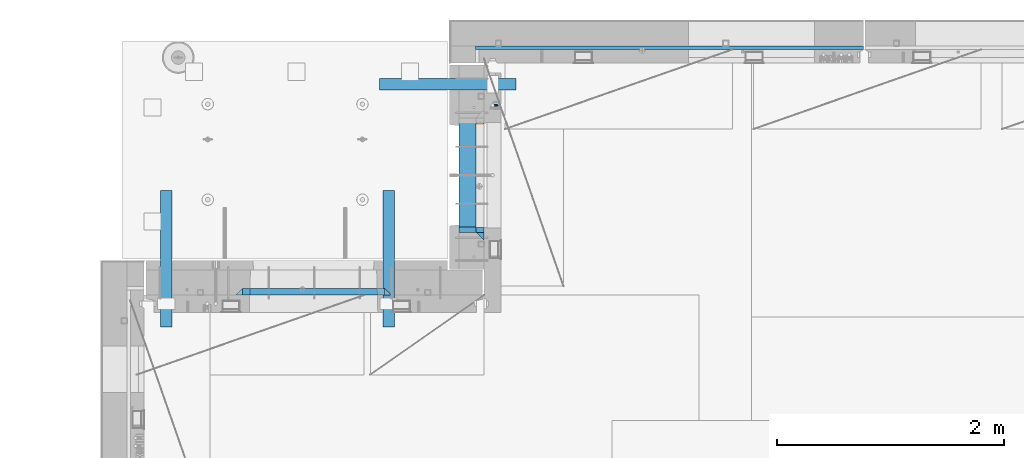
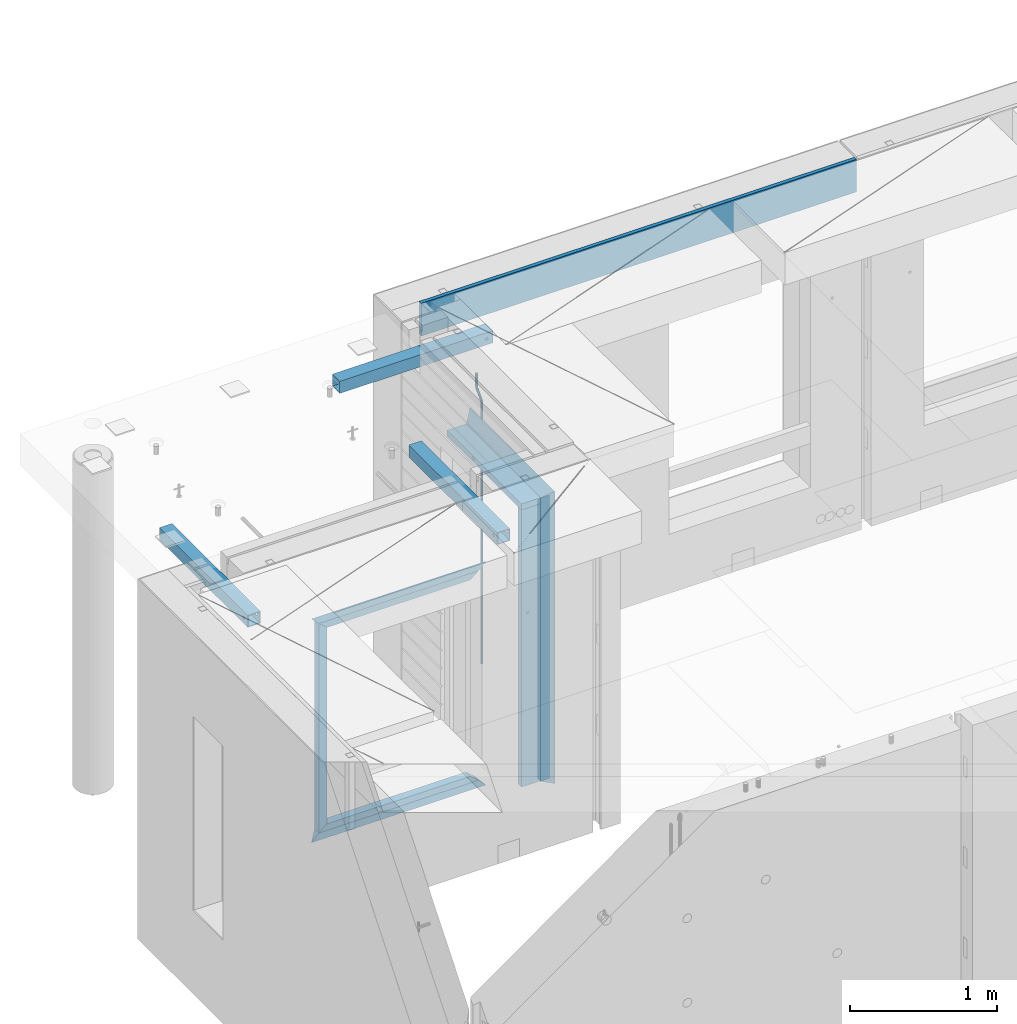
# One storey, part 99 of 309: 15 beams, 7 elements without a shape of their own.
"""IFC2X3 building model written with IfcOpenShell, lengths in millimetres."""

from ifc_helpers import new_model, si_unit, frame, origin_with_axes, place, context, subcontext, project, spatial, faceted_brep, material, type_object, element, aggregate, save


model = new_model("IFC2X3")

# Units and contexts
model_context = context("Model", 3, precision=1e-05, world=origin_with_axes())
body_context = subcontext(model_context, "Body", "Model", "MODEL_VIEW")
ifc_project = project(units=[si_unit("LENGTHUNIT", "METRE", prefix="MILLI"), si_unit("AREAUNIT", "SQUARE_METRE"), si_unit("VOLUMEUNIT", "CUBIC_METRE"), si_unit("MASSUNIT", "GRAM", prefix="KILO"), si_unit("TIMEUNIT", "SECOND"), si_unit("PLANEANGLEUNIT", "RADIAN"), si_unit("SOLIDANGLEUNIT", "STERADIAN"), si_unit("THERMODYNAMICTEMPERATUREUNIT", "DEGREE_CELSIUS"), si_unit("LUMINOUSINTENSITYUNIT", "LUMEN")], contexts=[model_context])

# Site, building, storey
site_placement = place(None, origin_with_axes())
site = spatial("IfcSite", under=ifc_project, at=site_placement, CompositionType="ELEMENT")
building_placement = place(site_placement, origin_with_axes())
building = spatial("IfcBuilding", under=site, at=building_placement, CompositionType="ELEMENT")
storey_placement = place(building_placement, origin_with_axes())
storey = spatial("IfcBuildingStorey", under=building, at=storey_placement, Name="7", CompositionType="ELEMENT", Elevation=0.0)

# Assembly, beams
assembly_1_placement = place(storey_placement, origin_with_axes())
assembly_1 = element("IfcElementAssembly", 1, at=assembly_1_placement, inside=storey, AssemblyPlace="NOTDEFINED", PredefinedType="REINFORCEMENT_UNIT")
ifc_material_1 = material(Name="CONCRETE/C25/30")
beam_type_1 = type_object("IfcBeamType", PredefinedType="NOTDEFINED")
beam_1_placement = place(assembly_1_placement, frame((10955.0, 22209.9998901814, 102140.0), z_axis=(0.0, 0.0, -1.0), x_axis=(0.0, -1.0, 0.0)))
beam_1 = element("IfcBeam", 2, at=beam_1_placement, type_object=beam_type_1, material=ifc_material_1, Name="SK", context=body_context, shape_type="Brep", body=[
    faceted_brep([(70.0000000000164, -35.0, 35.0), (70.0000000000164, 35.0, 35.0), (0.0, -35.0, -35.0), (1079.99961853027, -35.0, 35.0), (1079.99961853027, 35.0, 35.0), (1149.99961853027, -35.0, -35.0)], [[[0, 1, 2]], [[1, 0, 3, 4]], [[2, 1, 4, 5]], [[0, 2, 5, 3]], [[5, 4, 3]]]),
])
beam_2_placement = place(assembly_1_placement, frame((10955.0, 21095.0002716511, 102175.0), z_axis=(0.0, 1.0, 0.0), x_axis=(0.0, 0.0, -1.0)))
beam_2 = element("IfcBeam", 3, at=beam_2_placement, type_object=beam_type_1, material=ifc_material_1, Name="SK", context=body_context, shape_type="Brep", body=[
    faceted_brep([(2420.0, -35.0, 35.0), (2420.0, -35.0, -35.0), (2420.0, 35.0, 35.0), (70.0000000000164, -35.0, 35.0), (0.0, -35.0, -35.0), (70.0000000000164, 35.0, 35.0)], [[[0, 1, 2]], [[1, 0, 3, 4]], [[2, 1, 4, 5]], [[0, 2, 5, 3]], [[3, 5, 4]]]),
])
beam_type_2 = type_object("IfcBeamType", PredefinedType="NOTDEFINED")
beam_3_placement = place(assembly_1_placement, frame((10955.0, 21155.0002716511, 102105.0), z_axis=(0.0, 1.0, 0.0), x_axis=(0.0, 0.0, -1.0)))
beam_3 = element("IfcBeam", 4, at=beam_3_placement, type_object=beam_type_2, material=ifc_material_1, Name="SK", context=body_context, shape_type="Brep", body=[
    faceted_brep([(2350.0, -35.0, -25.0), (2350.0, 35.0, -25.0), (2350.0, 35.0, 20.6410256410309), (2350.0, -35.0, 18.8461538461561), (43.8461538461561, -35.0, 18.8461538461543), (0.0, -35.0, -25.0), (0.0, 35.0, -25.0), (45.6410256410309, 35.0, 20.6410256410254)], [[[0, 1, 2, 3]], [[0, 3, 4, 5]], [[1, 0, 5, 6]], [[2, 1, 6, 7]], [[3, 2, 7, 4]], [[7, 6, 5, 4]]]),
])
ifc_material_2 = material(Name="TIMBER")
beam_type_3 = type_object("IfcBeamType", Name="50X150", PredefinedType="NOTDEFINED")
beam_4_placement = place(assembly_1_placement, frame((10845.0, 22139.9998901814, 102080.0), z_axis=(0.0, 0.0, -1.0), x_axis=(0.0, -1.0, 0.0)))
beam_4 = element("IfcBeam", 5, at=beam_4_placement, type_object=beam_type_3, material=ifc_material_2, ObjectType="50X150", context=body_context, shape_type="Brep", body=[
    faceted_brep([(0.0, 75.0, -25.0), (1.81898940354586e-12, 75.0, 25.0), (1009.99961853027, 75.0, 25.0), (1009.99961853027, 75.0, -25.0), (1.81898940354586e-12, -75.0000000000009, 25.0), (1009.99961853027, -75.0, 25.0), (0.0, -75.0, -25.0), (1009.99961853027, -75.0, -25.0)], [[[0, 1, 2, 3]], [[1, 4, 5, 2]], [[4, 6, 7, 5]], [[6, 0, 3, 7]], [[5, 7, 3, 2]], [[6, 4, 1, 0]]]),
])
beam_5_placement = place(assembly_1_placement, frame((10845.0, 21155.0002716511, 102055.0), z_axis=(0.0, 1.0, 0.0), x_axis=(0.0, 0.0, -1.0)))
beam_5 = element("IfcBeam", 6, at=beam_5_placement, type_object=beam_type_3, material=ifc_material_2, ObjectType="50X150", context=body_context, shape_type="Brep", body=[
    faceted_brep([(0.0, 75.0, -25.0), (1.81898940354586e-12, 75.0, 25.0), (2295.00000000001, 75.0, 25.0), (2295.0, 75.0, -25.0), (1.81898940354586e-12, -75.0000000000009, 25.0), (2295.00000000001, -75.0, 25.0), (0.0, -75.0, -25.0), (2295.0, -75.0, -25.0)], [[[0, 1, 2, 3]], [[1, 4, 5, 2]], [[4, 6, 7, 5]], [[6, 0, 3, 7]], [[5, 7, 3, 2]], [[6, 4, 1, 0]]]),
])
ifc_material_3 = material()
beam_type_4 = type_object("IfcBeamType", Name="D20", PredefinedType="NOTDEFINED")
beam_6_placement = place(assembly_1_placement, frame((11065.0, 22249.9963332647, 102407.5), z_axis=(0.999999913638316, -0.000415599999849952, 0.0), x_axis=(0.0, 0.0, -1.0)))
beam_6 = element("IfcBeam", 7, at=beam_6_placement, type_object=beam_type_4, material=ifc_material_3, Name="JM20", ObjectType="D20", context=body_context, shape_type="Brep", body=[
    faceted_brep([(0.0, -10.0, 0.0), (-4.19531716033816e-08, -7.07106781186667, -7.07106781187031), (113.248091332178, -7.0710684840451, -7.0710678117357), (113.248091314759, -10.0000006713562, -2.51020537689328e-10), (0.0, 0.0, -10.0), (113.248091374131, -6.72178430249915e-07, -9.99999999986903), (4.196772351861e-08, 7.07106781186303, -7.07106781186667), (113.248091416113, 7.07106713968824, -7.07106781173934), (0.0, 10.0, 0.0), (113.248091433488, 9.99999932782521, 1.30967237055302e-10), (4.196772351861e-08, 7.07106781185939, 7.07106781185939), (113.248091416113, 7.0710671396846, 7.071067811994), (0.0, 0.0, 10.0), (113.248091374131, -6.72174792271107e-07, 10.0000000001273), (-4.19531716033816e-08, -7.07106781187031, 7.07106781185939), (113.248091332178, -7.0710684840451, 7.071067811994), (130.699843527167, -7.06993249763036, -4.33745683788584), (128.538066582521, -9.99900540317321, 2.39499413731755), (131.594536475241, 0.00119355250353692, -7.12624594330919), (130.698046432328, 7.07220300913468, -4.33773834422391), (128.535525107087, 10.0009944322555, 2.39459602660281), (126.373748162892, 7.07192152754578, 9.1270470011732), (125.479055214906, 0.000795477419160306, 11.9158361066184), (126.37554525779, -7.07021397921199, 9.12732850753673), (240.336258550378, -7.05529970173666, 30.8729495437874), (238.174481606227, -9.98437260450009, 37.6054005176375), (241.230951498423, 0.0158263482953771, 28.0841604381058), (240.334461455612, 7.0868358050102, 30.8726680369582), (238.171940130502, 10.0156272283348, 37.6050024077231), (236.010163186409, 7.08655432384694, 44.3374533824244), (235.115470238379, 0.0154282738185429, 47.1262424881097), (236.011960281176, -7.05558118289991, 44.3377348892536), (253.461915329972, -7.05444528127919, 32.9289287376414), (253.46191532613, -9.98337746617108, 39.9999965521893), (253.461915339081, 0.0166225284556276, 29.9999965443676), (253.461915348205, 7.08769034247234, 32.9289287273205), (253.461915352003, 10.0166225357716, 39.9999965370152), (253.461915348293, 7.08769035281148, 47.0710643509774), (253.461915339183, 0.0166225430875784, 49.999996544273), (253.46191533003, -7.05444527093641, 47.0710643613093), (2417.50000002384, -7.0544364694706, 32.9289287374122), (2417.5000000337, -9.98336865393321, 39.9999965507959), (2417.49999999997, 0.0166313408753922, 29.9999965456082), (2417.49999997609, 7.08769915426274, 32.9289287300708), (2417.4999999662, 10.0166313460668, 39.9999965404204), (2417.49999997608, 7.08769916160054, 47.0710643538114), (2417.49999999994, 0.0166313512581837, 49.9999965456154), (2417.50000002382, -7.05443646212916, 47.0710643611455)], [[[0, 1, 2, 3]], [[1, 4, 5, 2]], [[4, 6, 7, 5]], [[6, 8, 9, 7]], [[8, 10, 11, 9]], [[10, 12, 13, 11]], [[12, 14, 15, 13]], [[14, 0, 3, 15]], [[14, 12, 10, 8, 6, 4, 1, 0]], [[3, 2, 16, 17]], [[2, 5, 18, 16]], [[5, 7, 19, 18]], [[7, 9, 20, 19]], [[9, 11, 21, 20]], [[11, 13, 22, 21]], [[13, 15, 23, 22]], [[15, 3, 17, 23]], [[17, 16, 24, 25]], [[16, 18, 26, 24]], [[18, 19, 27, 26]], [[19, 20, 28, 27]], [[20, 21, 29, 28]], [[21, 22, 30, 29]], [[22, 23, 31, 30]], [[23, 17, 25, 31]], [[25, 24, 32, 33]], [[24, 26, 34, 32]], [[26, 27, 35, 34]], [[27, 28, 36, 35]], [[28, 29, 37, 36]], [[29, 30, 38, 37]], [[30, 31, 39, 38]], [[31, 25, 33, 39]], [[33, 32, 40, 41]], [[32, 34, 42, 40]], [[34, 35, 43, 42]], [[35, 36, 44, 43]], [[36, 37, 45, 44]], [[37, 38, 46, 45]], [[38, 39, 47, 46]], [[39, 33, 41, 47]], [[42, 43, 44, 45, 46, 47, 41, 40]]]),
])
aggregate(assembly_1, [beam_6, beam_1, beam_2, beam_3, beam_4, beam_5])

# Assemblies, beams
assembly_2_placement = place(storey_placement, origin_with_axes())
assembly_2 = element("IfcElementAssembly", 8, at=assembly_2_placement, inside=storey, AssemblyPlace="NOTDEFINED", PredefinedType="REINFORCEMENT_UNIT")
assembly_3_placement = place(assembly_2_placement, origin_with_axes())
assembly_3 = element("IfcElementAssembly", 9, at=assembly_3_placement, AssemblyPlace="NOTDEFINED", PredefinedType="NOTDEFINED")
ifc_material_4 = material(Name="Undefined/350")
beam_type_5 = type_object("IfcBeamType", Name="100X100X5", PredefinedType="NOTDEFINED")
beam_7_placement = place(assembly_3_placement, frame((10069.9865573969, 22435.0401432011, 102555.0), z_axis=(0.0, 0.0, 1.0), x_axis=(0.999999999752625, -2.22429999942101e-05, 0.0)))
beam_7 = element("IfcBeam", 10, at=beam_7_placement, type_object=beam_type_5, material=ifc_material_4, ObjectType="100X100X5", context=body_context, shape_type="Brep", body=[
    faceted_brep([(1156.2510802317, 44.9999999999982, 10.8253175473074), (1156.25107855315, 50.0256005946221, 10.8253175473074), (1160.82639610046, 50.0256021227788, 6.25), (1160.82639777901, 44.9999999999982, 6.25), (1150.00108023171, 44.9999999999982, 12.5), (1150.00107855316, 50.0255985071226, 12.5), (1143.75108023171, 44.9999999999982, 10.8253175473074), (1143.75107855316, 50.0255964196231, 10.8253175473074), (1139.1757626844, 44.9999999999982, 6.25), (1139.17576100585, 50.0255948914664, 6.25), (1137.5010802317, 44.9999999999982, 0.0), (1137.50107855316, 50.0255943321226, 0.0), (1139.1757626844, 44.9999999999982, -6.25), (1139.17576100585, 50.0255948914664, -6.25), (1143.75108023171, 44.9999999999982, -10.8253175473074), (1143.75107855316, 50.0255964196231, -10.8253175473074), (1150.00108023171, 44.9999999999982, -12.5), (1150.00107855316, 50.0255985071226, -12.5), (1156.2510802317, 44.9999999999982, -10.8253175473074), (1156.25107855315, 50.0256005946221, -10.8253175473074), (1160.82639777901, 44.9999999999982, -6.25), (1160.82639610046, 50.0256021227788, -6.25), (1162.50108023171, 44.9999999999982, 0.0), (1162.50107855316, 50.0256026821226, 0.0), (1156.25111195316, -49.9743994042774, 10.8253175473074), (1156.25111029171, -44.9999999999991, 10.8253175473074), (1160.82642783901, -44.9999999999991, 6.25), (1160.82642950046, -49.9743978761207, 6.25), (1150.00111195316, -49.9744014917787, 12.5), (1150.00111029171, -44.9999999999991, 12.5), (1143.75111195316, -49.9744035792783, 10.8253175473074), (1143.75111029171, -44.9999999999991, 10.8253175473074), (1139.17579440585, -49.9744051074349, 6.25), (1139.1757927444, -44.9999999999991, 6.25), (1137.50111195316, -49.9744056667778, 0.0), (1137.50111029171, -44.9999999999991, 0.0), (1139.17579440585, -49.9744051074349, -6.25), (1139.1757927444, -44.9999999999991, -6.25), (1143.75111195316, -49.9744035792783, -10.8253175473074), (1143.75111029171, -44.9999999999991, -10.8253175473074), (1150.00111195316, -49.9744014917787, -12.5), (1150.00111029171, -44.9999999999991, -12.5), (1156.25111195316, -49.9743994042774, -10.8253175473074), (1156.25111029171, -44.9999999999991, -10.8253175473074), (1160.82642950046, -49.9743978761207, -6.25), (1160.82642783901, -44.9999999999991, -6.25), (1162.50111195316, -49.9743973167779, 0.0), (1162.50111029171, -44.9999999999991, 0.0), (1.81898940354586e-12, -50.0000000000009, -50.0), (1.81898940354586e-12, 49.9999999999991, -50.0), (1200.00449189278, 49.9999999999982, -50.0), (1200.00449189278, -50.0000000000009, -50.0), (1.81898940354586e-12, 49.9999999999991, 50.0), (1.81898940354586e-12, -50.0000000000009, 50.0), (1200.00449189278, -50.0000000000009, 50.0), (1200.00449189278, 49.9999999999982, 50.0), (0.0, 44.9999999999991, 45.0), (1.81898940354586e-12, -45.0000000000009, 45.0), (1.81898940354586e-12, -45.0000000000009, -45.0), (0.0, 44.9999999999991, -45.0), (1200.00449189278, 44.9999999999982, -45.0), (1200.00449189278, 44.9999999999982, 45.0), (1200.00449189278, -45.0000000000009, 45.0), (1200.00449189278, -45.0000000000009, -45.0)], [[[0, 1, 2, 3]], [[4, 5, 1, 0]], [[6, 7, 5, 4]], [[8, 9, 7, 6]], [[10, 11, 9, 8]], [[12, 13, 11, 10]], [[14, 15, 13, 12]], [[16, 17, 15, 14]], [[18, 19, 17, 16]], [[20, 21, 19, 18]], [[22, 23, 21, 20]], [[3, 2, 23, 22]], [[24, 25, 26, 27]], [[28, 29, 25, 24]], [[30, 31, 29, 28]], [[32, 33, 31, 30]], [[34, 35, 33, 32]], [[36, 37, 35, 34]], [[38, 39, 37, 36]], [[40, 41, 39, 38]], [[42, 43, 41, 40]], [[44, 45, 43, 42]], [[46, 47, 45, 44]], [[27, 26, 47, 46]], [[48, 49, 50, 51]], [[52, 53, 54, 55]], [[49, 52, 55, 50], [1, 5, 7, 9, 11, 13, 15, 17, 19, 21, 23, 2]], [[48, 53, 52, 49], [56, 57, 58, 59]], [[56, 59, 60, 61], [18, 16, 14, 12, 10, 8, 6, 4, 0, 3, 22, 20]], [[57, 56, 61, 62]], [[58, 57, 62, 63], [25, 29, 31, 33, 35, 37, 39, 41, 43, 45, 47, 26]], [[59, 58, 63, 60]], [[54, 51, 50, 55], [62, 61, 60, 63]], [[53, 48, 51, 54], [42, 40, 38, 36, 34, 32, 30, 28, 24, 27, 46, 44]]]),
])
aggregate(assembly_3, [beam_7])
assembly_4_placement = place(assembly_2_placement, origin_with_axes())
assembly_4 = element("IfcElementAssembly", 11, at=assembly_4_placement, AssemblyPlace="NOTDEFINED", PredefinedType="NOTDEFINED")
beam_8_placement = place(assembly_4_placement, frame((10150.0001432011, 21500.0034426031, 102555.0), z_axis=(0.0, 0.0, 1.0), x_axis=(-2.2242999997242e-05, -0.999999999752625, 0.0)))
beam_8 = element("IfcBeam", 12, at=beam_8_placement, type_object=beam_type_5, material=ifc_material_4, ObjectType="100X100X5", context=body_context, shape_type="Brep", body=[
    faceted_brep([(1143.75108023171, 44.9999999999982, -10.8253175473074), (1143.75107855316, 50.0255964196231, -10.8253175473074), (1139.17576100585, 50.0255948914664, -6.25), (1139.1757626844, 44.9999999999982, -6.25), (1150.00108023171, 44.9999999999982, -12.5), (1150.00107855316, 50.0255985071226, -12.5), (1156.2510802317, 44.9999999999982, -10.8253175473074), (1156.25107855315, 50.0256005946221, -10.8253175473074), (1160.82639777901, 44.9999999999982, -6.25), (1160.82639610046, 50.0256021227788, -6.25), (1162.50108023171, 44.9999999999982, 0.0), (1162.50107855316, 50.0256026821226, 0.0), (1160.82639777901, 44.9999999999982, 6.25), (1160.82639610046, 50.0256021227788, 6.25), (1156.2510802317, 44.9999999999982, 10.8253175473074), (1156.25107855315, 50.0256005946221, 10.8253175473074), (1150.00108023171, 44.9999999999982, 12.5), (1150.00107855316, 50.0255985071226, 12.5), (1143.75108023171, 44.9999999999982, 10.8253175473074), (1143.75107855316, 50.0255964196231, 10.8253175473074), (1139.1757626844, 44.9999999999982, 6.25), (1139.17576100585, 50.0255948914664, 6.25), (1137.5010802317, 44.9999999999982, 0.0), (1137.50107855316, 50.0255943321226, 0.0), (1143.75111195316, -49.9744035792783, -10.8253175473074), (1143.75111029171, -44.9999999999991, -10.8253175473074), (1139.1757927444, -44.9999999999991, -6.25), (1139.17579440585, -49.9744051074349, -6.25), (1150.00111195316, -49.9744014917787, -12.5), (1150.00111029171, -44.9999999999991, -12.5), (1156.25111195316, -49.9743994042774, -10.8253175473074), (1156.25111029171, -44.9999999999991, -10.8253175473074), (1160.82642950046, -49.9743978761207, -6.25), (1160.82642783901, -44.9999999999991, -6.25), (1162.50111195316, -49.9743973167779, 0.0), (1162.50111029171, -44.9999999999991, 0.0), (1160.82642950046, -49.9743978761207, 6.25), (1160.82642783901, -44.9999999999991, 6.25), (1156.25111195316, -49.9743994042774, 10.8253175473074), (1156.25111029171, -44.9999999999991, 10.8253175473074), (1150.00111195316, -49.9744014917787, 12.5), (1150.00111029171, -44.9999999999991, 12.5), (1143.75111195316, -49.9744035792783, 10.8253175473074), (1143.75111029171, -44.9999999999991, 10.8253175473074), (1139.17579440585, -49.9744051074349, 6.25), (1139.1757927444, -44.9999999999991, 6.25), (1137.50111195316, -49.9744056667778, 0.0), (1137.50111029171, -44.9999999999991, 0.0), (1.81898940354586e-12, -50.0000000000009, -50.0), (1.81898940354586e-12, 49.9999999999991, -50.0), (1200.00449189278, 49.9999999999982, -50.0), (1200.00449189278, -50.0000000000009, -50.0), (1.81898940354586e-12, 49.9999999999991, 50.0), (1.81898940354586e-12, -50.0000000000009, 50.0), (1200.00449189278, -50.0000000000009, 50.0), (1200.00449189278, 49.9999999999982, 50.0), (0.0, 44.9999999999991, 45.0), (1.81898940354586e-12, -45.0000000000009, 45.0), (1.81898940354586e-12, -45.0000000000009, -45.0), (0.0, 44.9999999999991, -45.0), (1200.00449189278, 44.9999999999982, -45.0), (1200.00449189278, 44.9999999999982, 45.0), (1200.00449189278, -45.0000000000009, 45.0), (1200.00449189278, -45.0000000000009, -45.0)], [[[0, 1, 2, 3]], [[4, 5, 1, 0]], [[6, 7, 5, 4]], [[8, 9, 7, 6]], [[10, 11, 9, 8]], [[12, 13, 11, 10]], [[14, 15, 13, 12]], [[16, 17, 15, 14]], [[18, 19, 17, 16]], [[20, 21, 19, 18]], [[22, 23, 21, 20]], [[3, 2, 23, 22]], [[24, 25, 26, 27]], [[28, 29, 25, 24]], [[30, 31, 29, 28]], [[32, 33, 31, 30]], [[34, 35, 33, 32]], [[36, 37, 35, 34]], [[38, 39, 37, 36]], [[40, 41, 39, 38]], [[42, 43, 41, 40]], [[44, 45, 43, 42]], [[46, 47, 45, 44]], [[27, 26, 47, 46]], [[48, 49, 50, 51]], [[52, 53, 54, 55]], [[49, 52, 55, 50], [15, 17, 19, 21, 23, 2, 1, 5, 7, 9, 11, 13]], [[48, 53, 52, 49], [56, 57, 58, 59]], [[56, 59, 60, 61], [6, 4, 0, 3, 22, 20, 18, 16, 14, 12, 10, 8]], [[57, 56, 61, 62]], [[58, 57, 62, 63], [39, 41, 43, 45, 47, 26, 25, 29, 31, 33, 35, 37]], [[59, 58, 63, 60]], [[54, 51, 50, 55], [62, 61, 60, 63]], [[53, 48, 51, 54], [30, 28, 24, 27, 46, 44, 42, 40, 38, 36, 34, 32]]]),
])
aggregate(assembly_4, [beam_8])
assembly_5_placement = place(assembly_2_placement, origin_with_axes())
assembly_5 = element("IfcElementAssembly", 13, at=assembly_5_placement, AssemblyPlace="NOTDEFINED", PredefinedType="NOTDEFINED")
aggregate(assembly_2, [assembly_3, assembly_4, assembly_5])
beam_9_placement = place(assembly_5_placement, frame((8195.00014320107, 21500.0034426031, 102555.0), z_axis=(0.0, 0.0, 1.0), x_axis=(-2.2242999997242e-05, -0.999999999752625, 0.0)))
beam_9 = element("IfcBeam", 14, at=beam_9_placement, type_object=beam_type_5, material=ifc_material_4, ObjectType="100X100X5", context=body_context, shape_type="Brep", body=[
    faceted_brep([(1143.75108023171, 44.9999999999982, -10.8253175473074), (1143.75107855316, 50.0255964196231, -10.8253175473074), (1139.17576100585, 50.0255948914664, -6.25), (1139.1757626844, 44.9999999999982, -6.25), (1150.00108023171, 44.9999999999982, -12.5), (1150.00107855316, 50.0255985071226, -12.5), (1156.2510802317, 44.9999999999982, -10.8253175473074), (1156.25107855315, 50.0256005946221, -10.8253175473074), (1160.82639777901, 44.9999999999982, -6.25), (1160.82639610046, 50.0256021227788, -6.25), (1162.50108023171, 44.9999999999982, 0.0), (1162.50107855316, 50.0256026821226, 0.0), (1160.82639777901, 44.9999999999982, 6.25), (1160.82639610046, 50.0256021227788, 6.25), (1156.2510802317, 44.9999999999982, 10.8253175473074), (1156.25107855315, 50.0256005946221, 10.8253175473074), (1150.00108023171, 44.9999999999982, 12.5), (1150.00107855316, 50.0255985071226, 12.5), (1143.75108023171, 44.9999999999982, 10.8253175473074), (1143.75107855316, 50.0255964196231, 10.8253175473074), (1139.1757626844, 44.9999999999982, 6.25), (1139.17576100585, 50.0255948914664, 6.25), (1137.5010802317, 44.9999999999982, 0.0), (1137.50107855316, 50.0255943321226, 0.0), (1143.75111195316, -49.9744035792783, -10.8253175473074), (1143.75111029171, -44.9999999999991, -10.8253175473074), (1139.1757927444, -44.9999999999991, -6.25), (1139.17579440585, -49.9744051074349, -6.25), (1150.00111195316, -49.9744014917787, -12.5), (1150.00111029171, -44.9999999999991, -12.5), (1156.25111195316, -49.9743994042774, -10.8253175473074), (1156.25111029171, -44.9999999999991, -10.8253175473074), (1160.82642950046, -49.9743978761207, -6.25), (1160.82642783901, -44.9999999999991, -6.25), (1162.50111195316, -49.9743973167779, 0.0), (1162.50111029171, -44.9999999999991, 0.0), (1160.82642950046, -49.9743978761207, 6.25), (1160.82642783901, -44.9999999999991, 6.25), (1156.25111195316, -49.9743994042774, 10.8253175473074), (1156.25111029171, -44.9999999999991, 10.8253175473074), (1150.00111195316, -49.9744014917787, 12.5), (1150.00111029171, -44.9999999999991, 12.5), (1143.75111195316, -49.9744035792783, 10.8253175473074), (1143.75111029171, -44.9999999999991, 10.8253175473074), (1139.17579440585, -49.9744051074349, 6.25), (1139.1757927444, -44.9999999999991, 6.25), (1137.50111195316, -49.9744056667778, 0.0), (1137.50111029171, -44.9999999999991, 0.0), (1.81898940354586e-12, -50.0000000000009, -50.0), (1.81898940354586e-12, 49.9999999999991, -50.0), (1200.00449189278, 49.9999999999982, -50.0), (1200.00449189278, -50.0000000000009, -50.0), (1.81898940354586e-12, 49.9999999999991, 50.0), (1.81898940354586e-12, -50.0000000000009, 50.0), (1200.00449189278, -50.0000000000009, 50.0), (1200.00449189278, 49.9999999999982, 50.0), (0.0, 44.9999999999991, 45.0), (1.81898940354586e-12, -45.0000000000009, 45.0), (1.81898940354586e-12, -45.0000000000009, -45.0), (0.0, 44.9999999999991, -45.0), (1200.00449189278, 44.9999999999982, -45.0), (1200.00449189278, 44.9999999999982, 45.0), (1200.00449189278, -45.0000000000009, 45.0), (1200.00449189278, -45.0000000000009, -45.0)], [[[0, 1, 2, 3]], [[4, 5, 1, 0]], [[6, 7, 5, 4]], [[8, 9, 7, 6]], [[10, 11, 9, 8]], [[12, 13, 11, 10]], [[14, 15, 13, 12]], [[16, 17, 15, 14]], [[18, 19, 17, 16]], [[20, 21, 19, 18]], [[22, 23, 21, 20]], [[3, 2, 23, 22]], [[24, 25, 26, 27]], [[28, 29, 25, 24]], [[30, 31, 29, 28]], [[32, 33, 31, 30]], [[34, 35, 33, 32]], [[36, 37, 35, 34]], [[38, 39, 37, 36]], [[40, 41, 39, 38]], [[42, 43, 41, 40]], [[44, 45, 43, 42]], [[46, 47, 45, 44]], [[27, 26, 47, 46]], [[48, 49, 50, 51]], [[52, 53, 54, 55]], [[49, 52, 55, 50], [15, 17, 19, 21, 23, 2, 1, 5, 7, 9, 11, 13]], [[48, 53, 52, 49], [56, 57, 58, 59]], [[56, 59, 60, 61], [6, 4, 0, 3, 22, 20, 18, 16, 14, 12, 10, 8]], [[57, 56, 61, 62]], [[58, 57, 62, 63], [39, 41, 43, 45, 47, 26, 25, 29, 31, 33, 35, 37]], [[59, 58, 63, 60]], [[54, 51, 50, 55], [62, 61, 60, 63]], [[53, 48, 51, 54], [30, 28, 24, 27, 46, 44, 42, 40, 38, 36, 34, 32]]]),
])
aggregate(assembly_5, [beam_9])

# Assembly, beams
assembly_6_placement = place(storey_placement, origin_with_axes())
assembly_6 = element("IfcElementAssembly", 15, at=assembly_6_placement, inside=storey, AssemblyPlace="NOTDEFINED", PredefinedType="REINFORCEMENT_UNIT")
beam_type_6 = type_object("IfcBeamType", PredefinedType="NOTDEFINED")
beam_10_placement = place(assembly_6_placement, frame((10174.9997107317, 20609.9951872276, 102145.0), z_axis=(0.0, 0.0, -1.0), x_axis=(-1.0, 3.00000001838171e-08, 0.0)))
beam_10 = element("IfcBeam", 16, at=beam_10_placement, type_object=beam_type_6, material=ifc_material_1, Name="SK", context=body_context, shape_type="Brep", body=[
    faceted_brep([(60.0000000000073, 30.0, 30.0), (0.0, -30.0, -30.0), (60.0000000000073, -30.0, 30.0), (1309.99847412109, 30.0, 30.0), (1369.99847412109, -30.0, -30.0), (1309.99847412109, -30.0, 30.0)], [[[0, 1, 2]], [[1, 0, 3, 4]], [[2, 1, 4, 5]], [[0, 2, 5, 3]], [[3, 5, 4]]]),
])
beam_11_placement = place(assembly_6_placement, frame((10114.9997107317, 20609.9951872276, 102085.0), z_axis=(0.0, 0.0, -1.0), x_axis=(-1.0, 3.00000001838171e-08, 0.0)))
beam_11 = element("IfcBeam", 17, at=beam_11_placement, type_object=beam_type_6, material=ifc_material_1, Name="SK", context=body_context, shape_type="Brep", body=[
    faceted_brep([(65.6741497967687, 29.999999998452, 26.2921283848846), (0.0, 30.0, -30.0), (0.0, -30.0, -30.0), (64.0525281752307, -29.999999998452, 24.9021669953072), (64.0525281752307, -29.999999998452, 24.0540540541406), (65.6741497967687, 29.999999998452, 25.6756756756804), (1185.94442006696, -29.999999998452, 24.0540540541406), (1184.32279844542, 29.999999998452, 25.6756756756804), (1184.32279844542, 29.999999998452, 26.2934362810629), (1249.99847412109, 29.999999998452, -30.0), (1249.99847412109, -29.999999998452, -30.0), (1185.94442006696, -29.999999998452, 24.9034748915001)], [[[0, 1, 2, 3]], [[4, 5, 0, 3]], [[6, 7, 5, 4]], [[1, 0, 5, 7, 8, 9]], [[2, 1, 9, 10]], [[6, 4, 3, 2, 10, 11]], [[7, 6, 11, 8]], [[9, 8, 11, 10]]]),
])
beam_12_placement = place(assembly_6_placement, frame((8805.00123661063, 20609.9951872276, 100350.0), z_axis=(0.0, 0.0, 1.0), x_axis=(1.0, 0.0, 0.0)))
beam_12 = element("IfcBeam", 18, at=beam_12_placement, type_object=beam_type_6, material=ifc_material_1, Name="SK", context=body_context, shape_type="Brep", body=[
    faceted_brep([(1309.99847412109, 30.0, 30.0), (1309.99847412109, -30.0, 30.0), (1369.99847412109, -30.0, -30.0), (60.0000000000073, 30.0, 30.0), (60.0000000000073, -30.0, 30.0), (0.0, -30.0, -30.0)], [[[0, 1, 2]], [[3, 4, 1, 0]], [[4, 5, 2, 1]], [[5, 3, 0, 2]], [[3, 5, 4]]]),
])
beam_13_placement = place(assembly_6_placement, frame((8865.00123661063, 20609.9951872276, 100410.0), z_axis=(0.0, 0.0, 1.0), x_axis=(1.0, 0.0, 0.0)))
beam_13 = element("IfcBeam", 19, at=beam_13_placement, type_object=beam_type_6, material=ifc_material_1, Name="SK", context=body_context, shape_type="Brep", body=[
    faceted_brep([(1184.32432432433, 29.999999998452, 26.2921283848846), (1185.94594594586, -29.999999998452, 24.9021669952926), (1249.99847412109, -29.999999998452, -30.0), (1249.99847412109, 29.999999998452, -30.0), (1184.32432432432, 29.9999988381387, 25.6756756756804), (1185.94594588314, -29.9999988381387, 24.0540541168593), (65.6756756756768, 30.0, 25.6756756756804), (64.0540540540533, -30.0, 24.0540540540533), (65.6756756756768, 30.0, 26.293436281092), (64.0540540540533, -30.0, 24.9034748914419), (0.0, -30.0, -30.0), (0.0, 30.0, -30.0)], [[[0, 1, 2, 3]], [[4, 5, 1, 0]], [[5, 4, 6, 7]], [[7, 6, 8, 9]], [[2, 1, 5, 7, 9, 10]], [[10, 11, 3, 2]], [[6, 4, 0, 3, 11, 8]], [[10, 9, 8, 11]]]),
])
beam_type_7 = type_object("IfcBeamType", PredefinedType="NOTDEFINED")
beam_14_placement = place(assembly_6_placement, frame((8900.00123661063, 20609.9951872276, 102115.0), z_axis=(1.0, 0.0, 0.0), x_axis=(0.0, 0.0, -1.0)))
beam_14 = element("IfcBeam", 20, at=beam_14_placement, type_object=beam_type_7, material=ifc_material_1, Name="SK", context=body_context, shape_type="Brep", body=[
    faceted_brep([(0.0, -30.0, -35.0), (54.9034748914273, -30.0, 29.0540540540533), (56.2934362811066, 30.0, 30.6756756756768), (0.0, 30.0, -35.0), (1678.70656371891, 30.0, 30.6756756756768), (1735.0, 30.0, -35.0), (1735.0, -30.0, -35.0), (1680.09652510857, -30.0, 29.0540540540533)], [[[0, 1, 2, 3]], [[3, 2, 4, 5]], [[5, 6, 0, 3]], [[1, 0, 6, 7]], [[2, 1, 7, 4]], [[6, 5, 4, 7]]]),
])
aggregate(assembly_6, [beam_10, beam_11, beam_14, beam_12, beam_13])

# Assembly, beam
assembly_7_placement = place(storey_placement, origin_with_axes())
assembly_7 = element("IfcElementAssembly", 21, at=assembly_7_placement, inside=storey, AssemblyPlace="NOTDEFINED", PredefinedType="REINFORCEMENT_UNIT")
beam_type_8 = type_object("IfcBeamType", Name="270X30", PredefinedType="NOTDEFINED")
beam_15_placement = place(assembly_7_placement, frame((14325.0, 22755.0, 102605.0), z_axis=(0.0, 0.0, 1.0), x_axis=(-1.0, 3.00000001838171e-08, 0.0)))
beam_15 = element("IfcBeam", 22, at=beam_15_placement, type_object=beam_type_8, material=ifc_material_1, ObjectType="270X30", context=body_context, shape_type="Brep", body=[
    faceted_brep([(0.0, 15.0, -135.0), (0.0, 15.0, 135.0), (3410.00000000003, 15.0, 135.0), (3410.00000000003, 15.0, -135.0), (0.0, -15.0, 135.0), (3410.00000000003, -15.0, 135.0), (0.0, -15.0, -135.0), (3410.00000000003, -15.0, -135.0)], [[[0, 1, 2, 3]], [[1, 4, 5, 2]], [[4, 6, 7, 5]], [[6, 0, 3, 7]], [[5, 7, 3, 2]], [[6, 4, 1, 0]]]),
])
aggregate(assembly_7, [beam_15])

save(model, "model.ifc")
